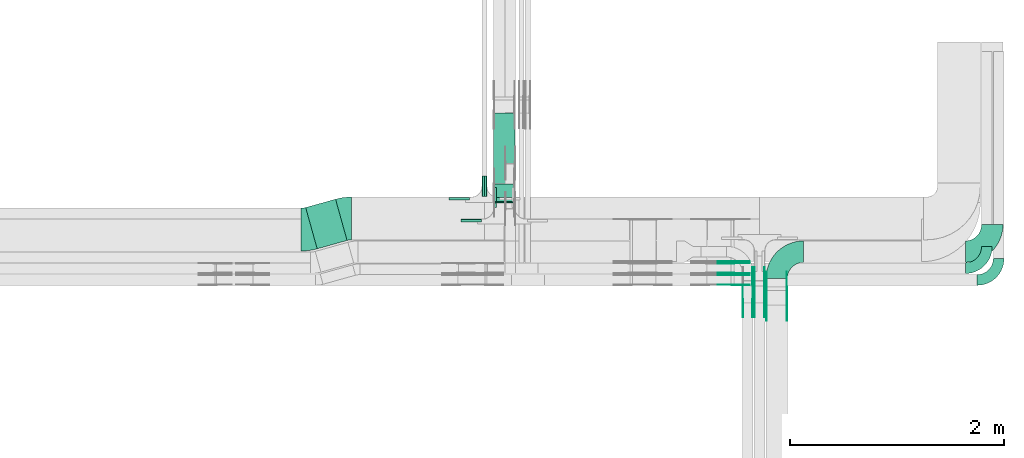
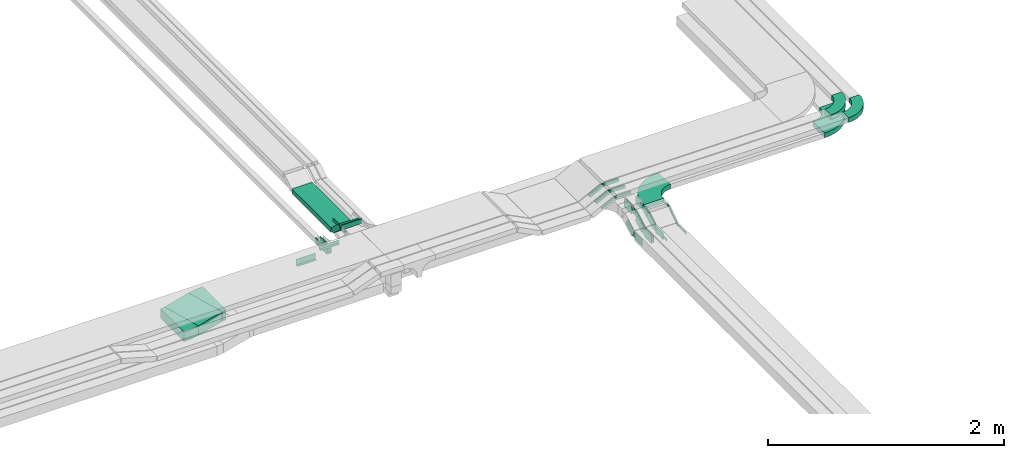
# One storey, part 23 of 27: 42 flow fittings, 4 flow segments.
"""IFC2X3 building model written with IfcOpenShell, lengths in millimetres."""

import ifcopenshell
import ifcopenshell.guid

model = None  # the IFC model being written
_history = None  # IfcOwnerHistory: only IFC2X3 demands one
_inside = {}  # id of a spatial element -> (the spatial element, [elements in it])
_under = {}  # id of a project, library or spatial element -> (it, [spatial elements below it])
_declared = {}  # id of a project -> (the project, [libraries it declares])
_typed = {}  # id of a type object -> (the type object, [elements of that type])
_made_of = {}  # id of a material, layer set ... -> (it, [elements and type objects made of it])


def new_model(schema):
    """Start an empty IFC model of exactly this schema.

    Asked for "IFC4X3", IfcOpenShell would pick the latest addendum, in which some entities
    have other attributes; the version numbers below select the first issue.
    IFC2X3 requires an IfcOwnerHistory on every rooted entity: one is made here for all.
    """
    global model, _history
    if schema == "IFC4X3":
        model = ifcopenshell.file(schema_version=(4, 3, 0, 0))
    else:
        model = ifcopenshell.file(schema=schema)
    _inside.clear()
    _under.clear()
    _declared.clear()
    _typed.clear()
    _made_of.clear()
    _history = None
    if model.schema == "IFC2X3":
        org = make("IfcOrganization", Name="unknown")
        user = make(
            "IfcPersonAndOrganization",
            ThePerson=make("IfcPerson", FamilyName="unknown"),
            TheOrganization=org,
        )
        app = make(
            "IfcApplication",
            ApplicationDeveloper=org,
            Version="unknown",
            ApplicationFullName="unknown",
            ApplicationIdentifier="unknown",
        )
        _history = make(
            "IfcOwnerHistory",
            OwningUser=user,
            OwningApplication=app,
            ChangeAction="ADDED",
            CreationDate=0,
        )
    return model


def make(cls, **values):
    """One entity of the class cls with the attributes given. An attribute that is None is left unset."""
    return model.create_entity(
        cls, **{name: value for name, value in values.items() if value is not None}
    )


def entity(cls, *values):
    """Any entity or typed value of the class cls, its attributes in the order of the schema. None: left unset."""
    e = model.create_entity(cls)
    for i, value in enumerate(values):
        if value is not None:
            e[i] = value
    return e


def rooted(cls, **values):
    """An entity with a GlobalId (a new one), such as an element, a storey or a relation."""
    return make(cls, GlobalId=ifcopenshell.guid.new(), OwnerHistory=_history, **values)


def si_unit(unit_type, name, prefix=None):
    """IfcSIUnit, for example si_unit("LENGTHUNIT", "METRE", prefix="MILLI")."""
    return make("IfcSIUnit", UnitType=unit_type, Prefix=prefix, Name=name)


def converted_unit(unit_type, name, factor, base, dimensions=None, offset=None):
    """IfcConversionBasedUnit, such as the inch: factor (a typed value) times the base unit."""
    return make(
        "IfcConversionBasedUnit"
        if offset is None
        else "IfcConversionBasedUnitWithOffset",
        ConversionOffset=offset,
        Dimensions=None
        if dimensions is None
        else entity("IfcDimensionalExponents", *dimensions),
        UnitType=unit_type,
        Name=name,
        ConversionFactor=make(
            "IfcMeasureWithUnit", ValueComponent=factor, UnitComponent=base
        ),
    )


def derived_unit(unit_type, elements):
    """IfcDerivedUnit: a product of units, each with its exponent."""
    return make(
        "IfcDerivedUnit",
        Elements=[
            make("IfcDerivedUnitElement", Unit=unit, Exponent=power)
            for unit, power in elements
        ],
        UnitType=unit_type,
    )


def assignment(units):
    """IfcUnitAssignment: the units of a project."""
    return None if units is None else make("IfcUnitAssignment", Units=units)


def point(xyz):
    """IfcCartesianPoint."""
    return None if xyz is None else make("IfcCartesianPoint", Coordinates=xyz)


def direction(xyz):
    """IfcDirection."""
    return None if xyz is None else make("IfcDirection", DirectionRatios=xyz)


def frame(location, z_axis=None, x_axis=None):
    """IfcAxis2Placement3D, a coordinate frame: its origin and axes. An axis left out is left unset."""
    return make(
        "IfcAxis2Placement3D",
        Location=point(location),
        Axis=direction(z_axis),
        RefDirection=direction(x_axis),
    )


def frame_2d(location, x_axis=None):
    """IfcAxis2Placement2D, a coordinate frame in the plane: its origin and x axis."""
    return make(
        "IfcAxis2Placement2D", Location=point(location), RefDirection=direction(x_axis)
    )


def origin():
    """The frame at (0, 0, 0) with its axes left unset."""
    return frame((0.0, 0.0, 0.0))


def origin_2d_with_axis():
    """The frame at (0, 0) in the plane with the x axis (1, 0) written out."""
    return frame_2d((0.0, 0.0), x_axis=(1.0, 0.0))


def place(relative_to, where):
    """IfcLocalPlacement: puts the frame where relative to a parent placement (None: the world)."""
    return make(
        "IfcLocalPlacement", PlacementRelTo=relative_to, RelativePlacement=where
    )


def context(
    kind, dimensions, precision=None, world=None, true_north=None, identifier=None
):
    """IfcGeometricRepresentationContext, for example the 3D "Model" context."""
    return make(
        "IfcGeometricRepresentationContext",
        ContextIdentifier=identifier,
        ContextType=kind,
        CoordinateSpaceDimension=dimensions,
        Precision=precision,
        WorldCoordinateSystem=world,
        TrueNorth=true_north,
    )


def subcontext(parent, identifier, kind, view, scale=None):
    """IfcGeometricRepresentationSubContext, for example "Body" below "Model"."""
    return make(
        "IfcGeometricRepresentationSubContext",
        ContextIdentifier=identifier,
        ContextType=kind,
        ParentContext=parent,
        TargetScale=scale,
        TargetView=view,
    )


def project(units=None, contexts=None):
    """IfcProject with its units and contexts."""
    return rooted(
        "IfcProject",
        Name="project",
        RepresentationContexts=contexts,
        UnitsInContext=assignment(units),
    )


def spatial(cls, under=None, at=None, **own):
    """A site, building, storey or space (cls), placed at a placement, below another one or the project."""
    s = rooted(cls, ObjectPlacement=at, **own)
    if under is not None:
        _under.setdefault(under.id(), (under, []))[1].append(s)
    return s


def polyline(points):
    """IfcPolyline through the points."""
    return make("IfcPolyline", Points=[point(p) for p in points])


def circle_curve(where, radius):
    """IfcCircle in the frame where."""
    return make("IfcCircle", Position=where, Radius=radius)


def parameter(value):
    """IfcParameterValue: where a trimmed curve begins or ends, as a parameter of its basis curve."""
    return model.create_entity("IfcParameterValue", value)


def trimmed(basis, trim1, trim2, sense, master):
    """IfcTrimmedCurve: the piece of a basis curve between two trims."""
    return make(
        "IfcTrimmedCurve",
        BasisCurve=basis,
        Trim1=trim1,
        Trim2=trim2,
        SenseAgreement=sense,
        MasterRepresentation=master,
    )


def segment(curve, same_sense, transition):
    """IfcCompositeCurveSegment."""
    return make(
        "IfcCompositeCurveSegment",
        Transition=transition,
        SameSense=same_sense,
        ParentCurve=curve,
    )


def composite_curve(segments, self_intersect=None):
    """IfcCompositeCurve: segments joined end to end."""
    return make("IfcCompositeCurve", Segments=segments, SelfIntersect=self_intersect)


def profile(cls, at=None, kind="AREA", **sizes):
    """A parametric profile (cls). Its sizes go by their IFC names, for example OverallWidth=200.0."""
    return make(cls, ProfileType=kind, Position=at, **sizes)


def rectangle(**sizes):
    """IfcRectangleProfileDef."""
    return profile("IfcRectangleProfileDef", **sizes)


def outline(outer, holes=None, kind="AREA"):
    """IfcArbitraryClosedProfileDef: a profile drawn as a closed curve; with holes, ...WithVoids."""
    if holes is None:
        return make("IfcArbitraryClosedProfileDef", ProfileType=kind, OuterCurve=outer)
    return make(
        "IfcArbitraryProfileDefWithVoids",
        ProfileType=kind,
        OuterCurve=outer,
        InnerCurves=holes,
    )


def extrude(swept, where, along, depth):
    """IfcExtrudedAreaSolid: the profile swept, set in the frame where, extruded along a direction by depth."""
    return make(
        "IfcExtrudedAreaSolid",
        SweptArea=swept,
        Position=where,
        ExtrudedDirection=direction(along),
        Depth=depth,
    )


def shape(context_of_items, identifier, shape_type, items):
    """IfcShapeRepresentation: the items that make up one representation, for example the "Body"."""
    return make(
        "IfcShapeRepresentation",
        ContextOfItems=context_of_items,
        RepresentationIdentifier=identifier,
        RepresentationType=shape_type,
        Items=items,
    )


def source(mapping_origin, context_of_items, identifier, shape_type, items):
    """IfcRepresentationMap: a shape defined once, which mapped items show again and again."""
    return make(
        "IfcRepresentationMap",
        MappingOrigin=mapping_origin,
        MappedRepresentation=shape(context_of_items, identifier, shape_type, items),
    )


def transform(
    local_origin,
    x_axis=None,
    y_axis=None,
    z_axis=None,
    scale=None,
    scale2=None,
    scale3=None,
    uniform=True,
):
    """IfcCartesianTransformationOperator3D, or its non-uniform kind. x_axis, y_axis, z_axis: its Axis1, 2, 3."""
    if uniform:
        return make(
            "IfcCartesianTransformationOperator3D",
            Axis1=direction(x_axis),
            Axis2=direction(y_axis),
            LocalOrigin=point(local_origin),
            Scale=scale,
            Axis3=direction(z_axis),
        )
    return make(
        "IfcCartesianTransformationOperator3DnonUniform",
        Axis1=direction(x_axis),
        Axis2=direction(y_axis),
        LocalOrigin=point(local_origin),
        Scale=scale,
        Axis3=direction(z_axis),
        Scale2=scale2,
        Scale3=scale3,
    )


def mapped(mapping_source, mapping_target):
    """IfcMappedItem: shows the shape of a source again, moved by a transform."""
    return make(
        "IfcMappedItem", MappingSource=mapping_source, MappingTarget=mapping_target
    )


def material(Name=None, Category=None):
    """IfcMaterial."""
    return make("IfcMaterial", Name=Name, Category=Category)


def made_of(thing, what):
    """Note that an element or type object is made of a material, layer set ...; save() writes the relation."""
    if what is not None:
        _made_of.setdefault(what.id(), (what, []))[1].append(thing)
    return thing


def type_object(cls, material=None, **own):
    """A type object (cls), such as IfcWallType, which elements share."""
    return made_of(rooted(cls, **own), material)


def type_shapes(of_type, sources):
    """Give a type object the sources (RepresentationMaps) that its elements show as mapped items."""
    of_type.RepresentationMaps = sources


def element(
    cls,
    number,
    at=None,
    inside=None,
    cuts=None,
    type_object=None,
    material=None,
    context=None,
    identifier="Body",
    shape_type=None,
    held_by="IfcProductDefinitionShape",
    body=None,
    shapes=None,
    **own,
):
    """One element of the class cls, such as IfcWall. Its Tag is "e" and its number.

    at: its placement. inside: the storey or other place that contains it. cuts: it is an
    opening in that element (IfcRelVoidsElement). A single representation is given by context,
    identifier, shape_type and body (its items); several are given by shapes. held_by: the class
    of the entity that holds the representations. save() writes the other relations.
    """
    e = rooted(cls, Tag="e%d" % number, ObjectPlacement=at, **own)
    if body is not None:
        shapes = [shape(context, identifier, shape_type, body)]
    if shapes is not None:
        e.Representation = make(held_by, Representations=shapes)
    if inside is not None:
        _inside.setdefault(inside.id(), (inside, []))[1].append(e)
    if cuts is not None:
        rooted(
            "IfcRelVoidsElement", RelatingBuildingElement=cuts, RelatedOpeningElement=e
        )
    if type_object is not None:
        _typed.setdefault(type_object.id(), (type_object, []))[1].append(e)
    return made_of(e, material)


def aggregate(whole, parts):
    """IfcRelAggregates: a whole, such as a stair, and the parts it consists of."""
    return rooted("IfcRelAggregates", RelatingObject=whole, RelatedObjects=parts)


def save(model, path):
    """Write the relations noted so far, then the file.

    IfcRelAggregates (storeys below a building ...), IfcRelContainedInSpatialStructure (elements
    in a storey), IfcRelDefinesByType, IfcRelAssociatesMaterial and IfcRelDeclares: one each for
    every whole, place, type object, material and project.
    """
    for whole, parts in _under.values():
        aggregate(whole, parts)
    for where, things in _inside.values():
        rooted(
            "IfcRelContainedInSpatialStructure",
            RelatedElements=things,
            RelatingStructure=where,
        )
    for kind, things in _typed.values():
        rooted("IfcRelDefinesByType", RelatedObjects=things, RelatingType=kind)
    for what, things in _made_of.values():
        rooted("IfcRelAssociatesMaterial", RelatedObjects=things, RelatingMaterial=what)
    for by, libraries in _declared.values():
        rooted("IfcRelDeclares", RelatingContext=by, RelatedDefinitions=libraries)
    model.write(path)


model = new_model("IFC2X3")

# Units and contexts
model_context = context("Model", 3, precision=0.01, world=origin(), true_north=direction((6.12303176911189e-17, 1.0)))
body_context = subcontext(model_context, "Body", "Model", "MODEL_VIEW")
ifc_project = project(units=[si_unit("LENGTHUNIT", "METRE", prefix="MILLI"), si_unit("AREAUNIT", "SQUARE_METRE"), si_unit("VOLUMEUNIT", "CUBIC_METRE"), converted_unit("PLANEANGLEUNIT", "DEGREE", entity("IfcRatioMeasure", 0.0174532925199433), si_unit("PLANEANGLEUNIT", "RADIAN"), dimensions=[0, 0, 0, 0, 0, 0, 0]), si_unit("MASSUNIT", "GRAM", prefix="KILO"), derived_unit("MASSDENSITYUNIT", [(si_unit("MASSUNIT", "GRAM", prefix="KILO"), 1), (si_unit("LENGTHUNIT", "METRE"), -3)]), derived_unit("MOMENTOFINERTIAUNIT", [(si_unit("LENGTHUNIT", "METRE"), 4)]), si_unit("TIMEUNIT", "SECOND"), si_unit("FREQUENCYUNIT", "HERTZ"), si_unit("THERMODYNAMICTEMPERATUREUNIT", "DEGREE_CELSIUS"), derived_unit("THERMALTRANSMITTANCEUNIT", [(si_unit("MASSUNIT", "GRAM", prefix="KILO"), 1), (si_unit("THERMODYNAMICTEMPERATUREUNIT", "KELVIN"), -1), (si_unit("TIMEUNIT", "SECOND"), -3)]), derived_unit("VOLUMETRICFLOWRATEUNIT", [(si_unit("LENGTHUNIT", "METRE"), 3), (si_unit("TIMEUNIT", "SECOND"), -1)]), derived_unit("MASSFLOWRATEUNIT", [(si_unit("MASSUNIT", "GRAM", prefix="KILO"), 1), (si_unit("TIMEUNIT", "SECOND"), -1)]), derived_unit("ROTATIONALFREQUENCYUNIT", [(si_unit("TIMEUNIT", "SECOND"), -1)]), si_unit("ELECTRICCURRENTUNIT", "AMPERE"), si_unit("ELECTRICVOLTAGEUNIT", "VOLT"), si_unit("POWERUNIT", "WATT"), si_unit("FORCEUNIT", "NEWTON", prefix="KILO"), si_unit("ILLUMINANCEUNIT", "LUX"), si_unit("LUMINOUSFLUXUNIT", "LUMEN"), si_unit("LUMINOUSINTENSITYUNIT", "CANDELA"), derived_unit("USERDEFINED", [(si_unit("MASSUNIT", "GRAM", prefix="KILO"), -1), (si_unit("LENGTHUNIT", "METRE"), -2), (si_unit("TIMEUNIT", "SECOND"), 3), (si_unit("LUMINOUSFLUXUNIT", "LUMEN"), 1)]), derived_unit("LINEARVELOCITYUNIT", [(si_unit("LENGTHUNIT", "METRE"), 1), (si_unit("TIMEUNIT", "SECOND"), -1)]), si_unit("PRESSUREUNIT", "PASCAL"), derived_unit("USERDEFINED", [(si_unit("LENGTHUNIT", "METRE"), -2), (si_unit("MASSUNIT", "GRAM", prefix="KILO"), 1), (si_unit("TIMEUNIT", "SECOND"), -2)]), derived_unit("LINEARFORCEUNIT", [(si_unit("MASSUNIT", "GRAM", prefix="KILO"), 1), (si_unit("LENGTHUNIT", "METRE"), 1), (si_unit("TIMEUNIT", "SECOND"), -2), (si_unit("LENGTHUNIT", "METRE"), -1)]), derived_unit("PLANARFORCEUNIT", [(si_unit("MASSUNIT", "GRAM", prefix="KILO"), 1), (si_unit("LENGTHUNIT", "METRE"), 1), (si_unit("TIMEUNIT", "SECOND"), -2), (si_unit("LENGTHUNIT", "METRE"), -2)])], contexts=[model_context])

# Site, building, storey
site_placement = place(None, origin())
site = spatial("IfcSite", under=ifc_project, at=site_placement, CompositionType="ELEMENT")
building_placement = place(site_placement, origin())
building = spatial("IfcBuilding", under=site, at=building_placement, CompositionType="ELEMENT")
storey_placement = place(building_placement, origin())
storey = spatial("IfcBuildingStorey", under=building, at=storey_placement, CompositionType="ELEMENT", Elevation=0.0)

# Flow segments
cable_carrier_segment_type = type_object("IfcCableCarrierSegmentType", PredefinedType="CABLETRAYSEGMENT")
flow_segment_1_placement = place(storey_placement, frame((62148.39, 8640.69, 2600.0)))
element("IfcFlowSegment", 1, at=flow_segment_1_placement, inside=storey, type_object=cable_carrier_segment_type, context=body_context, shape_type="SweptSolid", body=[
    extrude(rectangle(XDim=289.546419624688, YDim=399.999999999996, at=origin_2d_with_axis()), frame((193.21, 231.56, 0.0), z_axis=(0.0, 0.0, 1.0), x_axis=(0.963181508900078, 0.26885196840077, 0.0)), (0.0, 0.0, 1.0), 100.0),
])
flow_segment_2_placement = place(storey_placement, frame((63902.18, 9070.0, 2850.0)))
element("IfcFlowSegment", 2, at=flow_segment_2_placement, inside=storey, type_object=cable_carrier_segment_type, context=body_context, shape_type="SweptSolid", body=[
    extrude(rectangle(XDim=9.65396886623574, YDim=200.000000000007, at=origin_2d_with_axis()), frame((100.0, 4.83, 0.0), z_axis=(0.0, 0.0, 1.0), x_axis=(0.0, -1.0, 0.0)), (0.0, 0.0, 1.0), 50.0000000000005),
])
flow_segment_3_placement = place(storey_placement, frame((63902.18, 9084.07, 2734.08)))
element("IfcFlowSegment", 3, at=flow_segment_3_placement, inside=storey, type_object=cable_carrier_segment_type, context=body_context, shape_type="SweptSolid", body=[
    extrude(rectangle(XDim=49.9999999999991, YDim=170.698727057013, at=frame_2d((0.0, 0.0), x_axis=(0.0, 1.0))), frame((0.0, 80.16, 75.69), z_axis=(1.0, 0.0, 0.0), x_axis=(0.0, 0.743144825477238, -0.669130606359032)), (0.0, 0.0, 1.0), 200.000000000007),
])
flow_segment_4_placement = place(storey_placement, frame((63902.18, 9248.8, 2719.54)))
element("IfcFlowSegment", 4, at=flow_segment_4_placement, inside=storey, type_object=cable_carrier_segment_type, context=body_context, shape_type="SweptSolid", body=[
    extrude(rectangle(XDim=658.860589157185, YDim=200.000000000007, at=origin_2d_with_axis()), frame((100.0, 329.43, 0.0), z_axis=(0.0, 0.0, 1.0), x_axis=(0.0, 1.0, 0.0)), (0.0, 0.0, 1.0), 49.9999999999995),
])

# Flow fittings
ifc_material_1 = material()
cable_carrier_fitting_type_1 = type_object("IfcCableCarrierFittingType", PredefinedType="NOTDEFINED", material=ifc_material_1)
shared_shape_1 = source(origin(), body_context, "Body", "SweptSolid", [
    extrude(outline(polyline([(-9.17, -21.5), (15.83, -21.5), (15.83, -19.0), (-6.67, -19.0), (-6.67, 40.5), (-9.17, 40.5), (-9.17, -21.5)])), frame((-95.0, 9.17, -26.0), z_axis=(1.0, 0.0, 0.0), x_axis=(0.0, 1.0, 0.0)), (0.0, 0.0, 1.0), 190.0),
])
type_shapes(cable_carrier_fitting_type_1, [shared_shape_1])
for number, where, z_axis, x_axis in (
    (5, (63794.68, 9224.33, 2650.0), (0.0, 0.0, 1.0), (0.0, -1.0, 0.0)),
    (6, (63839.68, 9224.33, 2650.0), (0.0, 0.0, 1.0), (0.0, 1.0, 0.0)),
):
    element("IfcFlowFitting", number, at=place(storey_placement, frame(where, z_axis=z_axis, x_axis=x_axis)), inside=storey, type_object=cable_carrier_fitting_type_1, material=ifc_material_1, context=body_context, shape_type="MappedRepresentation", body=[
        mapped(shared_shape_1, transform((0.0, 0.0, 0.0), scale=1.0)),
    ])
cable_carrier_fitting_type_2 = type_object("IfcCableCarrierFittingType", PredefinedType="NOTDEFINED", material=ifc_material_1)
shared_shape_2 = source(origin(), body_context, "Body", "SweptSolid", [
    extrude(outline(polyline([(-21.5, -9.17), (40.5, -9.17), (40.5, -6.67), (-19.0, -6.67), (-19.0, 15.83), (-21.5, 15.83), (-21.5, -9.17)])), frame((-95.0, -9.17, -26.0), z_axis=(1.0, 0.0, 0.0), x_axis=(0.0, 0.0, 1.0)), (0.0, 0.0, 1.0), 190.0),
])
type_shapes(cable_carrier_fitting_type_2, [shared_shape_2])
flow_fitting_1_placement = place(storey_placement, frame((63582.18, 9121.83, 2650.0)))
element("IfcFlowFitting", 7, at=flow_fitting_1_placement, inside=storey, type_object=cable_carrier_fitting_type_2, material=ifc_material_1, context=body_context, shape_type="MappedRepresentation", body=[
    mapped(shared_shape_2, transform((0.0, 0.0, 0.0), scale=1.0)),
])
cable_carrier_fitting_type_3 = type_object("IfcCableCarrierFittingType", PredefinedType="NOTDEFINED", material=ifc_material_1)
shared_shape_3 = source(origin(), body_context, "Body", "SweptSolid", [
    extrude(outline(polyline([(-9.17, -11.5), (15.83, -11.5), (15.83, -9.0), (-6.67, -9.0), (-6.67, 20.5), (-9.17, 20.5), (-9.17, -11.5)])), frame((-95.0, 9.17, -11.0), z_axis=(1.0, 0.0, 0.0), x_axis=(0.0, 1.0, 0.0)), (0.0, 0.0, 1.0), 190.0),
])
type_shapes(cable_carrier_fitting_type_3, [shared_shape_3])
flow_fitting_2_placement = place(storey_placement, frame((63904.68, 9120.0, 2875.0), z_axis=(0.0, 0.0, 1.0), x_axis=(0.0, -1.0, 0.0)))
element("IfcFlowFitting", 8, at=flow_fitting_2_placement, inside=storey, type_object=cable_carrier_fitting_type_3, material=ifc_material_1, context=body_context, shape_type="MappedRepresentation", body=[
    mapped(shared_shape_3, transform((0.0, 0.0, 0.0), scale=1.0)),
])
cable_carrier_fitting_type_4 = type_object("IfcCableCarrierFittingType", PredefinedType="NOTDEFINED", material=ifc_material_1)
shared_shape_4 = source(origin(), body_context, "Body", "SweptSolid", [
    extrude(outline(polyline([(-11.5, -9.17), (20.5, -9.17), (20.5, -6.67), (-9.0, -6.67), (-9.0, 15.83), (-11.5, 15.83), (-11.5, -9.17)])), frame((-95.0, -9.17, -11.0), z_axis=(1.0, 0.0, 0.0), x_axis=(0.0, 0.0, 1.0)), (0.0, 0.0, 1.0), 190.0),
])
type_shapes(cable_carrier_fitting_type_4, [shared_shape_4])
flow_fitting_3_placement = place(storey_placement, frame((63692.18, 8917.5, 2875.0)))
element("IfcFlowFitting", 9, at=flow_fitting_3_placement, inside=storey, type_object=cable_carrier_fitting_type_4, material=ifc_material_1, context=body_context, shape_type="MappedRepresentation", body=[
    mapped(shared_shape_4, transform((0.0, 0.0, 0.0), scale=1.0)),
])
ifc_material_2 = material()
cable_carrier_fitting_type_5 = type_object("IfcCableCarrierFittingType", Name="470_DKC_S5_Variable Angle Elbow 0-45:-", PredefinedType="NOTDEFINED", material=ifc_material_2)
shared_shape_5 = source(origin(), body_context, "Body", "SweptSolid", [
    extrude(outline(composite_curve([segment(polyline([(-100.75, -150.25), (-99.75, -150.25)]), True, "CONTINUOUS"), segment(trimmed(circle_curve(frame_2d((-99.75, 99.75), x_axis=(0.0, -1.0)), 250.0), [parameter(0.0)], [parameter(90.0000000000001)], True, "PARAMETER"), True, "CONTINUOUS"), segment(polyline([(150.25, 99.75), (150.25, 100.75)]), True, "CONTINUOUS"), segment(polyline([(150.25, 100.75), (50.25, 100.75)]), True, "CONTINUOUS"), segment(polyline([(50.25, 100.75), (50.25, 99.75)]), True, "CONTINUOUS"), segment(trimmed(circle_curve(frame_2d((-99.75, 99.75), x_axis=(0.0, -1.0)), 150.0), [parameter(0.0)], [parameter(90.0000000000001)], True, "PARAMETER"), False, "CONTINUOUS"), segment(polyline([(-99.75, -50.25), (-100.75, -50.25)]), True, "CONTINUOUS"), segment(polyline([(-100.75, -50.25), (-100.75, -150.25)]), True, "CONTINUOUS")], self_intersect=False)), frame((-100.25, 100.25, -25.0)), (0.0, 0.0, 1.0), 49.9999999999997),
])
type_shapes(cable_carrier_fitting_type_5, [shared_shape_5])
for number, where, name in (
    (10, (68616.01, 8350.0, 2875.0), "470_DKC_S5_Variable Angle Elbow 0-45:-"),
    (11, (68506.01, 8460.0, 2875.0), "470_DKC_S5_Variable Angle Elbow 0-45:-"),
):
    element("IfcFlowFitting", number, at=place(storey_placement, frame(where)), inside=storey, type_object=cable_carrier_fitting_type_5, material=ifc_material_2, Name=name, ObjectType="470_DKC_S5_Variable Angle Elbow 0-45:-", context=body_context, shape_type="MappedRepresentation", body=[
        mapped(shared_shape_5, transform((0.0, 0.0, 0.0), scale=1.0)),
    ])
ifc_material_3 = material(Name="G")
cable_carrier_fitting_type_6 = type_object("IfcCableCarrierFittingType", PredefinedType="NOTDEFINED", material=ifc_material_3)
shared_shape_6 = source(origin(), body_context, "Body", "SweptSolid", [
    extrude(outline(composite_curve([segment(trimmed(circle_curve(frame_2d((-44.59, 0.0), x_axis=(1.0, 0.0)), 12.5), [parameter(90.0000000000007)], [parameter(270.0)], True, "PARAMETER"), True, "CONTINUOUS"), segment(polyline([(-44.59, -12.5), (-33.09, -12.5)]), True, "CONTINUOUS"), segment(polyline([(-33.09, -12.5), (-31.23, -14.5)]), True, "CONTINUOUS"), segment(polyline([(-31.23, -14.5), (108.91, -14.5)]), True, "CONTINUOUS"), segment(polyline([(108.91, -14.5), (108.91, 14.5)]), True, "CONTINUOUS"), segment(polyline([(108.91, 14.5), (-31.23, 14.5)]), True, "CONTINUOUS"), segment(polyline([(-31.23, 14.5), (-33.09, 12.5)]), True, "CONTINUOUS"), segment(polyline([(-33.09, 12.5), (-44.59, 12.5)]), True, "CONTINUOUS")], self_intersect=False)), frame((44.59, 0.0, 0.0), z_axis=(0.0, 0.0, -1.0), x_axis=(1.0, 0.0, 0.0)), (0.0, 0.0, -1.0), 2.0),
])
type_shapes(cable_carrier_fitting_type_6, [shared_shape_6])
flow_fitting_4_placement = place(storey_placement, frame((66640.46, 8274.33, 2625.0), z_axis=(1.0, 0.0, 0.0), x_axis=(0.0, -0.831466573945132, -0.555574780215899)))
element("IfcFlowFitting", 12, at=flow_fitting_4_placement, inside=storey, type_object=cable_carrier_fitting_type_6, material=ifc_material_3, context=body_context, shape_type="MappedRepresentation", body=[
    mapped(shared_shape_6, transform((0.0, 0.0, 0.0), scale=1.0)),
])
cable_carrier_fitting_type_7 = type_object("IfcCableCarrierFittingType", PredefinedType="NOTDEFINED", material=ifc_material_3)
type_shapes(cable_carrier_fitting_type_7, [shared_shape_6])
flow_fitting_5_placement = place(storey_placement, frame((66451.54, 8274.33, 2625.0), z_axis=(-1.0, 0.0, 0.0), x_axis=(0.0, 1.0, 0.0)))
element("IfcFlowFitting", 13, at=flow_fitting_5_placement, inside=storey, type_object=cable_carrier_fitting_type_7, material=ifc_material_3, context=body_context, shape_type="MappedRepresentation", body=[
    mapped(shared_shape_6, transform((0.0, 0.0, 0.0), scale=1.0)),
])
flow_fitting_6_placement = place(storey_placement, frame((66449.54, 8124.67, 2525.0), z_axis=(-1.0, 0.0, 0.0), x_axis=(0.0, -1.0, 0.0)))
element("IfcFlowFitting", 14, at=flow_fitting_6_placement, inside=storey, type_object=cable_carrier_fitting_type_6, material=ifc_material_3, context=body_context, shape_type="MappedRepresentation", body=[
    mapped(shared_shape_6, transform((0.0, 0.0, 0.0), scale=1.0)),
])
flow_fitting_7_placement = place(storey_placement, frame((66638.46, 8124.67, 2525.0), z_axis=(1.0, 0.0, 0.0), x_axis=(0.0, 0.831466573945084, 0.555574780215971)))
element("IfcFlowFitting", 15, at=flow_fitting_7_placement, inside=storey, type_object=cable_carrier_fitting_type_7, material=ifc_material_3, context=body_context, shape_type="MappedRepresentation", body=[
    mapped(shared_shape_6, transform((0.0, 0.0, 0.0), scale=1.0)),
])
flow_fitting_8_placement = place(storey_placement, frame((66137.29, 8395.46, 2875.0), z_axis=(0.0, 1.0, 0.0), x_axis=(1.0, 0.0, 0.0)))
element("IfcFlowFitting", 16, at=flow_fitting_8_placement, inside=storey, type_object=cable_carrier_fitting_type_6, material=ifc_material_3, context=body_context, shape_type="MappedRepresentation", body=[
    mapped(shared_shape_6, transform((0.0, 0.0, 0.0), scale=1.0)),
])
for number, where, z_axis, x_axis in (
    (17, (66137.29, 8306.54, 2875.0), (0.0, -1.0, 0.0), (-0.891006524188267, 0.0, -0.453990499739745)),
    (18, (66137.29, 8526.54, 2875.0), (0.0, -1.0, 0.0), (-0.891006524188393, 0.0, -0.453990499739498)),
):
    element("IfcFlowFitting", number, at=place(storey_placement, frame(where, z_axis=z_axis, x_axis=x_axis)), inside=storey, type_object=cable_carrier_fitting_type_7, material=ifc_material_3, context=body_context, shape_type="MappedRepresentation", body=[
        mapped(shared_shape_6, transform((0.0, 0.0, 0.0), scale=1.0)),
    ])
flow_fitting_9_placement = place(storey_placement, frame((66137.29, 8505.46, 2875.0), z_axis=(0.0, 1.0, 0.0), x_axis=(1.0, 0.0, 0.0)))
element("IfcFlowFitting", 19, at=flow_fitting_9_placement, inside=storey, type_object=cable_carrier_fitting_type_6, material=ifc_material_3, context=body_context, shape_type="MappedRepresentation", body=[
    mapped(shared_shape_6, transform((0.0, 0.0, 0.0), scale=1.0)),
])
flow_fitting_10_placement = place(storey_placement, frame((66137.29, 8416.54, 2875.0), z_axis=(0.0, -1.0, 0.0), x_axis=(-0.891006524188395, 0.0, -0.453990499739495)))
element("IfcFlowFitting", 20, at=flow_fitting_10_placement, inside=storey, type_object=cable_carrier_fitting_type_7, material=ifc_material_3, context=body_context, shape_type="MappedRepresentation", body=[
    mapped(shared_shape_6, transform((0.0, 0.0, 0.0), scale=1.0)),
])
cable_carrier_fitting_type_8 = type_object("IfcCableCarrierFittingType", PredefinedType="NOTDEFINED", material=ifc_material_3)
shared_shape_7 = source(origin(), body_context, "Body", "SweptSolid", [
    extrude(outline(composite_curve([segment(trimmed(circle_curve(frame_2d((-44.59, 0.0), x_axis=(1.0, 0.0)), 12.5), [parameter(90.0000000000007)], [parameter(270.0)], True, "PARAMETER"), True, "CONTINUOUS"), segment(polyline([(-44.59, -12.5), (-33.09, -12.5)]), True, "CONTINUOUS"), segment(polyline([(-33.09, -12.5), (-31.23, -14.5)]), True, "CONTINUOUS"), segment(polyline([(-31.23, -14.5), (108.91, -14.5)]), True, "CONTINUOUS"), segment(polyline([(108.91, -14.5), (108.91, 14.5)]), True, "CONTINUOUS"), segment(polyline([(108.91, 14.5), (-31.23, 14.5)]), True, "CONTINUOUS"), segment(polyline([(-31.23, 14.5), (-33.09, 12.5)]), True, "CONTINUOUS"), segment(polyline([(-33.09, 12.5), (-44.59, 12.5)]), True, "CONTINUOUS")], self_intersect=False)), frame((44.59, 0.0, 0.0)), (0.0, 0.0, 1.0), 2.0),
])
type_shapes(cable_carrier_fitting_type_8, [shared_shape_7])
flow_fitting_11_placement = place(storey_placement, frame((66449.54, 8274.33, 2625.0), z_axis=(-1.0, 0.0, 0.0), x_axis=(0.0, -0.831466573945132, -0.555574780215899)))
element("IfcFlowFitting", 21, at=flow_fitting_11_placement, inside=storey, type_object=cable_carrier_fitting_type_8, material=ifc_material_3, context=body_context, shape_type="MappedRepresentation", body=[
    mapped(shared_shape_7, transform((0.0, 0.0, 0.0), scale=1.0)),
])
cable_carrier_fitting_type_9 = type_object("IfcCableCarrierFittingType", PredefinedType="NOTDEFINED", material=ifc_material_3)
type_shapes(cable_carrier_fitting_type_9, [shared_shape_7])
flow_fitting_12_placement = place(storey_placement, frame((66638.46, 8274.33, 2625.0), z_axis=(1.0, 0.0, 0.0), x_axis=(0.0, 1.0, 0.0)))
element("IfcFlowFitting", 22, at=flow_fitting_12_placement, inside=storey, type_object=cable_carrier_fitting_type_9, material=ifc_material_3, context=body_context, shape_type="MappedRepresentation", body=[
    mapped(shared_shape_7, transform((0.0, 0.0, 0.0), scale=1.0)),
])
flow_fitting_13_placement = place(storey_placement, frame((66640.46, 8124.67, 2525.0), z_axis=(1.0, 0.0, 0.0), x_axis=(0.0, -1.0, 0.0)))
element("IfcFlowFitting", 23, at=flow_fitting_13_placement, inside=storey, type_object=cable_carrier_fitting_type_8, material=ifc_material_3, context=body_context, shape_type="MappedRepresentation", body=[
    mapped(shared_shape_7, transform((0.0, 0.0, 0.0), scale=1.0)),
])
flow_fitting_14_placement = place(storey_placement, frame((66451.54, 8124.67, 2525.0), z_axis=(-1.0, 0.0, 0.0), x_axis=(0.0, 0.831466573945084, 0.555574780215971)))
element("IfcFlowFitting", 24, at=flow_fitting_14_placement, inside=storey, type_object=cable_carrier_fitting_type_9, material=ifc_material_3, context=body_context, shape_type="MappedRepresentation", body=[
    mapped(shared_shape_7, transform((0.0, 0.0, 0.0), scale=1.0)),
])
flow_fitting_15_placement = place(storey_placement, frame((66137.29, 8304.54, 2875.0), z_axis=(0.0, -1.0, 0.0), x_axis=(1.0, 0.0, 0.0)))
element("IfcFlowFitting", 25, at=flow_fitting_15_placement, inside=storey, type_object=cable_carrier_fitting_type_8, material=ifc_material_3, context=body_context, shape_type="MappedRepresentation", body=[
    mapped(shared_shape_7, transform((0.0, 0.0, 0.0), scale=1.0)),
])
flow_fitting_16_placement = place(storey_placement, frame((66137.29, 8393.46, 2875.0), z_axis=(0.0, 1.0, 0.0), x_axis=(-0.891006524188267, 0.0, -0.453990499739745)))
element("IfcFlowFitting", 26, at=flow_fitting_16_placement, inside=storey, type_object=cable_carrier_fitting_type_9, material=ifc_material_3, context=body_context, shape_type="MappedRepresentation", body=[
    mapped(shared_shape_7, transform((0.0, 0.0, 0.0), scale=1.0)),
])
for number, where, z_axis, x_axis in (
    (27, (66137.29, 8524.54, 2875.0), (0.0, -1.0, 0.0), (1.0, 0.0, 0.0)),
    (28, (66137.29, 8414.54, 2875.0), (0.0, -1.0, 0.0), (1.0, 0.0, 0.0)),
):
    element("IfcFlowFitting", number, at=place(storey_placement, frame(where, z_axis=z_axis, x_axis=x_axis)), inside=storey, type_object=cable_carrier_fitting_type_8, material=ifc_material_3, context=body_context, shape_type="MappedRepresentation", body=[
        mapped(shared_shape_7, transform((0.0, 0.0, 0.0), scale=1.0)),
    ])
flow_fitting_17_placement = place(storey_placement, frame((66137.29, 8503.46, 2875.0), z_axis=(0.0, 1.0, 0.0), x_axis=(-0.891006524188395, 0.0, -0.453990499739495)))
element("IfcFlowFitting", 29, at=flow_fitting_17_placement, inside=storey, type_object=cable_carrier_fitting_type_9, material=ifc_material_3, context=body_context, shape_type="MappedRepresentation", body=[
    mapped(shared_shape_7, transform((0.0, 0.0, 0.0), scale=1.0)),
])
cable_carrier_fitting_type_10 = type_object("IfcCableCarrierFittingType", Name="470_DKC_S5_Variable Angle Elbow 0-45:-", PredefinedType="NOTDEFINED", material=ifc_material_2)
shared_shape_8 = source(origin(), body_context, "Body", "SweptSolid", [
    extrude(outline(composite_curve([segment(polyline([(-125.75, -225.25), (-124.75, -225.25)]), True, "CONTINUOUS"), segment(trimmed(circle_curve(frame_2d((-124.75, 124.75), x_axis=(0.0, -1.0)), 350.0), [parameter(0.0)], [parameter(90.0000000000001)], True, "PARAMETER"), True, "CONTINUOUS"), segment(polyline([(225.25, 124.75), (225.25, 125.75)]), True, "CONTINUOUS"), segment(polyline([(225.25, 125.75), (25.25, 125.75)]), True, "CONTINUOUS"), segment(polyline([(25.25, 125.75), (25.25, 124.75)]), True, "CONTINUOUS"), segment(trimmed(circle_curve(frame_2d((-124.75, 124.75), x_axis=(0.0, -1.0)), 150.0), [parameter(0.0)], [parameter(90.0000000000001)], True, "PARAMETER"), False, "CONTINUOUS"), segment(polyline([(-124.75, -25.25), (-125.75, -25.25)]), True, "CONTINUOUS"), segment(polyline([(-125.75, -25.25), (-125.75, -225.25)]), True, "CONTINUOUS")], self_intersect=False)), frame((-125.25, 125.25, -25.0)), (0.0, 0.0, 1.0), 50.000000000001),
])
type_shapes(cable_carrier_fitting_type_10, [shared_shape_8])
flow_fitting_18_placement = place(storey_placement, frame((68556.01, 8614.33, 2625.0)))
element("IfcFlowFitting", 30, at=flow_fitting_18_placement, inside=storey, type_object=cable_carrier_fitting_type_10, material=ifc_material_2, Name="470_DKC_S5_Variable Angle Elbow 0-45:-", ObjectType="470_DKC_S5_Variable Angle Elbow 0-45:-", context=body_context, shape_type="MappedRepresentation", body=[
    mapped(shared_shape_8, transform((0.0, 0.0, 0.0), scale=1.0)),
])
flow_fitting_19_placement = place(storey_placement, frame((66545.0, 8614.33, 2625.0), z_axis=(0.0, 0.0, 1.0), x_axis=(-1.0, 0.0, 0.0)))
element("IfcFlowFitting", 31, at=flow_fitting_19_placement, inside=storey, type_object=cable_carrier_fitting_type_10, material=ifc_material_2, Name="470_DKC_S5_Variable Angle Elbow 0-45:-", ObjectType="470_DKC_S5_Variable Angle Elbow 0-45:-", context=body_context, shape_type="MappedRepresentation", body=[
    mapped(shared_shape_8, transform((0.0, 0.0, 0.0), scale=1.0)),
])
cable_carrier_fitting_type_11 = type_object("IfcCableCarrierFittingType", PredefinedType="NOTDEFINED", material=ifc_material_3)
shared_shape_9 = source(origin(), body_context, "Body", "SweptSolid", [
    extrude(outline(composite_curve([segment(trimmed(circle_curve(frame_2d((-41.47, 0.0), x_axis=(1.0, 0.0)), 25.0), [parameter(90.0000000000007)], [parameter(270.0)], True, "PARAMETER"), True, "CONTINUOUS"), segment(polyline([(-41.47, -25.0), (-29.97, -25.0)]), True, "CONTINUOUS"), segment(polyline([(-29.97, -25.0), (-28.1, -38.5)]), True, "CONTINUOUS"), segment(polyline([(-28.1, -38.5), (99.53, -38.5)]), True, "CONTINUOUS"), segment(polyline([(99.53, -38.5), (99.53, 38.5)]), True, "CONTINUOUS"), segment(polyline([(99.53, 38.5), (-28.1, 38.5)]), True, "CONTINUOUS"), segment(polyline([(-28.1, 38.5), (-29.97, 25.0)]), True, "CONTINUOUS"), segment(polyline([(-29.97, 25.0), (-41.47, 25.0)]), True, "CONTINUOUS")], self_intersect=False)), frame((41.47, 0.0, 0.0), z_axis=(0.0, 0.0, -1.0), x_axis=(1.0, 0.0, 0.0)), (0.0, 0.0, -1.0), 2.0),
])
type_shapes(cable_carrier_fitting_type_11, [shared_shape_9])
flow_fitting_20_placement = place(storey_placement, frame((66320.46, 8144.13, 2550.0), z_axis=(1.0, 0.0, 0.0), x_axis=(0.0, 0.880202910340009, 0.474597552278748)))
element("IfcFlowFitting", 32, at=flow_fitting_20_placement, inside=storey, type_object=cable_carrier_fitting_type_11, material=ifc_material_3, context=body_context, shape_type="MappedRepresentation", body=[
    mapped(shared_shape_9, transform((0.0, 0.0, 0.0), scale=1.0)),
])
cable_carrier_fitting_type_12 = type_object("IfcCableCarrierFittingType", PredefinedType="NOTDEFINED", material=ifc_material_3)
type_shapes(cable_carrier_fitting_type_12, [shared_shape_9])
flow_fitting_21_placement = place(storey_placement, frame((66231.54, 8144.13, 2550.0), z_axis=(-1.0, 0.0, 0.0), x_axis=(0.0, -1.0, 0.0)))
element("IfcFlowFitting", 33, at=flow_fitting_21_placement, inside=storey, type_object=cable_carrier_fitting_type_12, material=ifc_material_3, context=body_context, shape_type="MappedRepresentation", body=[
    mapped(shared_shape_9, transform((0.0, 0.0, 0.0), scale=1.0)),
])
flow_fitting_22_placement = place(storey_placement, frame((66339.54, 8329.6, 2650.0), z_axis=(-1.0, 0.0, 0.0), x_axis=(0.0, 1.0, 0.0)))
element("IfcFlowFitting", 34, at=flow_fitting_22_placement, inside=storey, type_object=cable_carrier_fitting_type_11, material=ifc_material_3, context=body_context, shape_type="MappedRepresentation", body=[
    mapped(shared_shape_9, transform((0.0, 0.0, 0.0), scale=1.0)),
])
flow_fitting_23_placement = place(storey_placement, frame((66428.46, 8329.6, 2650.0), z_axis=(1.0, 0.0, 0.0), x_axis=(0.0, -0.880202910340133, -0.474597552278517)))
element("IfcFlowFitting", 35, at=flow_fitting_23_placement, inside=storey, type_object=cable_carrier_fitting_type_12, material=ifc_material_3, context=body_context, shape_type="MappedRepresentation", body=[
    mapped(shared_shape_9, transform((0.0, 0.0, 0.0), scale=1.0)),
])
flow_fitting_24_placement = place(storey_placement, frame((66339.54, 8144.13, 2550.0), z_axis=(-1.0, 0.0, 0.0), x_axis=(0.0, -1.0, 0.0)))
element("IfcFlowFitting", 36, at=flow_fitting_24_placement, inside=storey, type_object=cable_carrier_fitting_type_11, material=ifc_material_3, context=body_context, shape_type="MappedRepresentation", body=[
    mapped(shared_shape_9, transform((0.0, 0.0, 0.0), scale=1.0)),
])
flow_fitting_25_placement = place(storey_placement, frame((66428.46, 8144.13, 2550.0), z_axis=(1.0, 0.0, 0.0), x_axis=(0.0, 0.880202910340084, 0.474597552278608)))
element("IfcFlowFitting", 37, at=flow_fitting_25_placement, inside=storey, type_object=cable_carrier_fitting_type_12, material=ifc_material_3, context=body_context, shape_type="MappedRepresentation", body=[
    mapped(shared_shape_9, transform((0.0, 0.0, 0.0), scale=1.0)),
])
cable_carrier_fitting_type_13 = type_object("IfcCableCarrierFittingType", PredefinedType="NOTDEFINED", material=ifc_material_3)
shared_shape_10 = source(origin(), body_context, "Body", "SweptSolid", [
    extrude(outline(composite_curve([segment(trimmed(circle_curve(frame_2d((-41.47, 0.0), x_axis=(1.0, 0.0)), 25.0), [parameter(90.0000000000007)], [parameter(270.0)], True, "PARAMETER"), True, "CONTINUOUS"), segment(polyline([(-41.47, -25.0), (-29.97, -25.0)]), True, "CONTINUOUS"), segment(polyline([(-29.97, -25.0), (-28.1, -38.5)]), True, "CONTINUOUS"), segment(polyline([(-28.1, -38.5), (99.53, -38.5)]), True, "CONTINUOUS"), segment(polyline([(99.53, -38.5), (99.53, 38.5)]), True, "CONTINUOUS"), segment(polyline([(99.53, 38.5), (-28.1, 38.5)]), True, "CONTINUOUS"), segment(polyline([(-28.1, 38.5), (-29.97, 25.0)]), True, "CONTINUOUS"), segment(polyline([(-29.97, 25.0), (-41.47, 25.0)]), True, "CONTINUOUS")], self_intersect=False)), frame((41.47, 0.0, 0.0)), (0.0, 0.0, 1.0), 2.0),
])
type_shapes(cable_carrier_fitting_type_13, [shared_shape_10])
flow_fitting_26_placement = place(storey_placement, frame((66318.46, 8329.6, 2650.0), z_axis=(1.0, 0.0, 0.0), x_axis=(0.0, 1.0, 0.0)))
element("IfcFlowFitting", 38, at=flow_fitting_26_placement, inside=storey, type_object=cable_carrier_fitting_type_13, material=ifc_material_3, context=body_context, shape_type="MappedRepresentation", body=[
    mapped(shared_shape_10, transform((0.0, 0.0, 0.0), scale=1.0)),
])
cable_carrier_fitting_type_14 = type_object("IfcCableCarrierFittingType", PredefinedType="NOTDEFINED", material=ifc_material_3)
type_shapes(cable_carrier_fitting_type_14, [shared_shape_10])
flow_fitting_27_placement = place(storey_placement, frame((66229.54, 8144.13, 2550.0), z_axis=(-1.0, 0.0, 0.0), x_axis=(0.0, 0.880202910340009, 0.474597552278748)))
element("IfcFlowFitting", 39, at=flow_fitting_27_placement, inside=storey, type_object=cable_carrier_fitting_type_14, material=ifc_material_3, context=body_context, shape_type="MappedRepresentation", body=[
    mapped(shared_shape_10, transform((0.0, 0.0, 0.0), scale=1.0)),
])
flow_fitting_28_placement = place(storey_placement, frame((66318.46, 8144.13, 2550.0), z_axis=(1.0, 0.0, 0.0), x_axis=(0.0, -1.0, 0.0)))
element("IfcFlowFitting", 40, at=flow_fitting_28_placement, inside=storey, type_object=cable_carrier_fitting_type_13, material=ifc_material_3, context=body_context, shape_type="MappedRepresentation", body=[
    mapped(shared_shape_10, transform((0.0, 0.0, 0.0), scale=1.0)),
])
flow_fitting_29_placement = place(storey_placement, frame((66430.46, 8329.6, 2650.0), z_axis=(1.0, 0.0, 0.0), x_axis=(0.0, 1.0, 0.0)))
element("IfcFlowFitting", 41, at=flow_fitting_29_placement, inside=storey, type_object=cable_carrier_fitting_type_14, material=ifc_material_3, context=body_context, shape_type="MappedRepresentation", body=[
    mapped(shared_shape_10, transform((0.0, 0.0, 0.0), scale=1.0)),
])
flow_fitting_30_placement = place(storey_placement, frame((66341.54, 8329.6, 2650.0), z_axis=(-1.0, 0.0, 0.0), x_axis=(0.0, -0.880202910340133, -0.474597552278517)))
element("IfcFlowFitting", 42, at=flow_fitting_30_placement, inside=storey, type_object=cable_carrier_fitting_type_13, material=ifc_material_3, context=body_context, shape_type="MappedRepresentation", body=[
    mapped(shared_shape_10, transform((0.0, 0.0, 0.0), scale=1.0)),
])
flow_fitting_31_placement = place(storey_placement, frame((66430.46, 8144.13, 2550.0), z_axis=(1.0, 0.0, 0.0), x_axis=(0.0, -1.0, 0.0)))
element("IfcFlowFitting", 43, at=flow_fitting_31_placement, inside=storey, type_object=cable_carrier_fitting_type_14, material=ifc_material_3, context=body_context, shape_type="MappedRepresentation", body=[
    mapped(shared_shape_10, transform((0.0, 0.0, 0.0), scale=1.0)),
])
flow_fitting_32_placement = place(storey_placement, frame((66341.54, 8144.13, 2550.0), z_axis=(-1.0, 0.0, 0.0), x_axis=(0.0, 0.880202910340084, 0.474597552278608)))
element("IfcFlowFitting", 44, at=flow_fitting_32_placement, inside=storey, type_object=cable_carrier_fitting_type_13, material=ifc_material_3, context=body_context, shape_type="MappedRepresentation", body=[
    mapped(shared_shape_10, transform((0.0, 0.0, 0.0), scale=1.0)),
])
cable_carrier_fitting_type_15 = type_object("IfcCableCarrierFittingType", Name="470_DKC_S5_Variable Angle Elbow 0-45:-", PredefinedType="NOTDEFINED", material=ifc_material_2)
shared_shape_11 = source(origin(), body_context, "Body", "SweptSolid", [
    extrude(outline(composite_curve([segment(polyline([(-48.04, -206.51), (-47.04, -206.51)]), True, "CONTINUOUS"), segment(trimmed(circle_curve(frame_2d((-47.04, 343.49), x_axis=(0.0, -1.0)), 550.0), [parameter(0.0)], [parameter(15.5959637059979)], True, "PARAMETER"), True, "CONTINUOUS"), segment(polyline([(100.83, -186.26), (101.79, -185.99)]), True, "CONTINUOUS"), segment(polyline([(101.79, -185.99), (-5.75, 199.28)]), True, "CONTINUOUS"), segment(polyline([(-5.75, 199.28), (-6.71, 199.01)]), True, "CONTINUOUS"), segment(trimmed(circle_curve(frame_2d((-47.04, 343.49), x_axis=(0.0, -1.0)), 150.0), [parameter(0.0)], [parameter(15.5959637059979)], True, "PARAMETER"), False, "CONTINUOUS"), segment(polyline([(-47.04, 193.49), (-48.04, 193.49)]), True, "CONTINUOUS"), segment(polyline([(-48.04, 193.49), (-48.04, -206.51)]), True, "CONTINUOUS")], self_intersect=False)), frame((-0.89, 6.51, -50.0)), (0.0, 0.0, 1.0), 99.999999999999),
])
type_shapes(cable_carrier_fitting_type_15, [shared_shape_11])
flow_fitting_33_placement = place(storey_placement, frame((62528.17, 8924.33, 2650.0), z_axis=(0.0, 0.0, 1.0), x_axis=(-1.0, 0.0, 0.0)))
element("IfcFlowFitting", 45, at=flow_fitting_33_placement, inside=storey, type_object=cable_carrier_fitting_type_15, material=ifc_material_2, Name="470_DKC_S5_Variable Angle Elbow 0-45:-", ObjectType="470_DKC_S5_Variable Angle Elbow 0-45:-", context=body_context, shape_type="MappedRepresentation", body=[
    mapped(shared_shape_11, transform((0.0, 0.0, 0.0), scale=1.0)),
])
flow_fitting_34_placement = place(storey_placement, frame((62155.03, 8820.17, 2650.0)))
element("IfcFlowFitting", 46, at=flow_fitting_34_placement, inside=storey, type_object=cable_carrier_fitting_type_15, material=ifc_material_2, Name="470_DKC_S5_Variable Angle Elbow 0-45:-", ObjectType="470_DKC_S5_Variable Angle Elbow 0-45:-", context=body_context, shape_type="MappedRepresentation", body=[
    mapped(shared_shape_11, transform((0.0, 0.0, 0.0), scale=1.0)),
])

save(model, "model.ifc")
